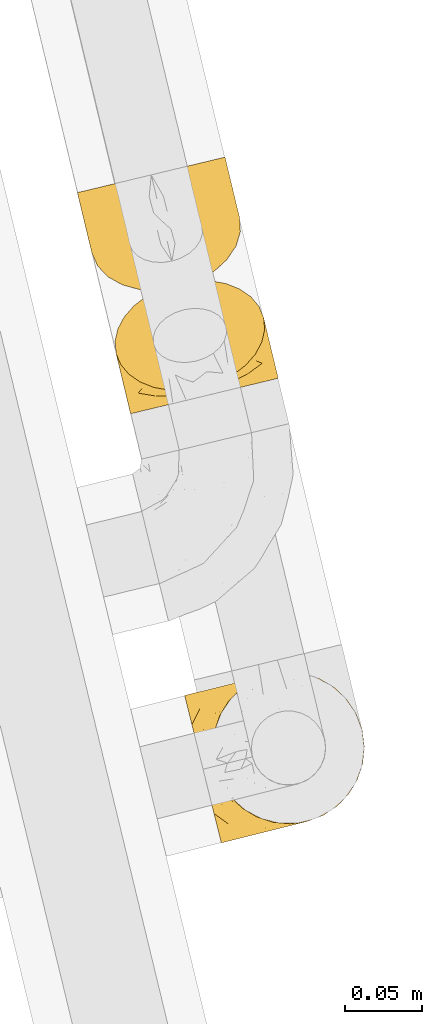
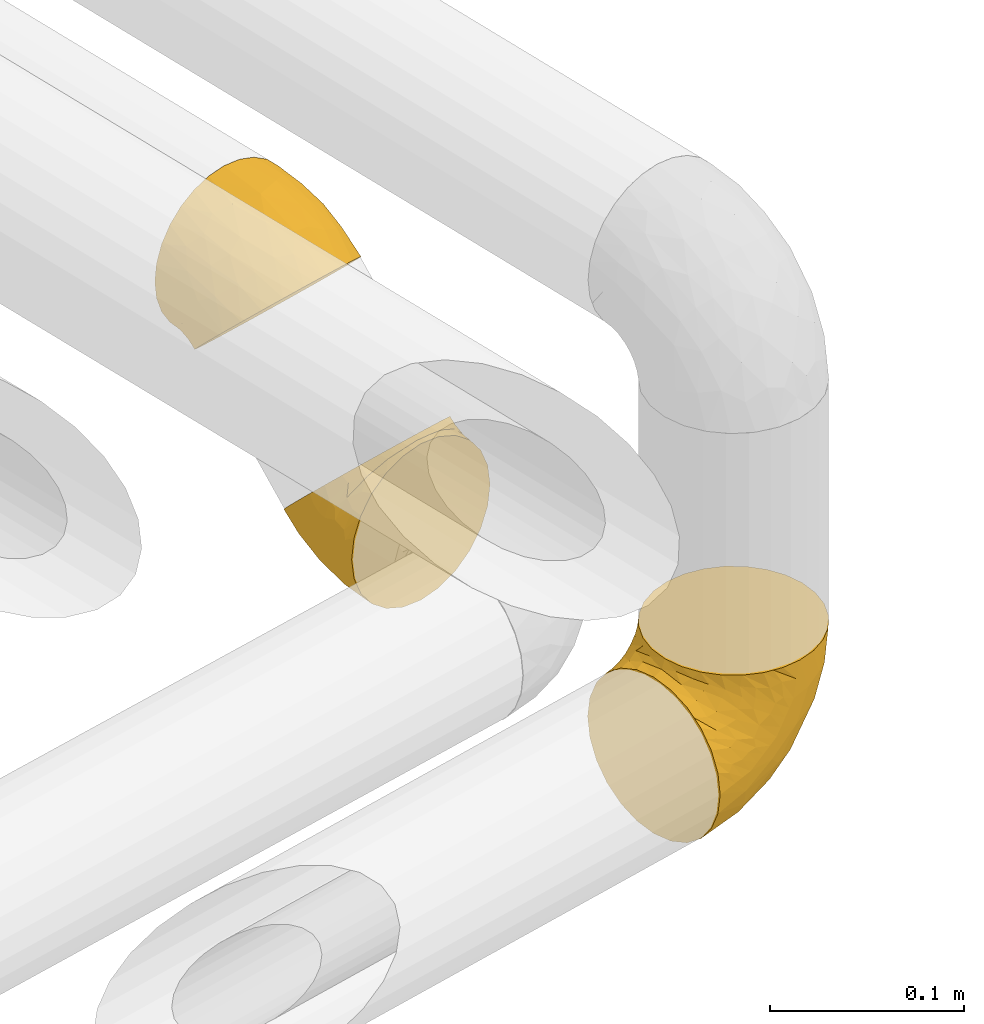
# One storey, part 8 of 93: 3 coverings.
"""IFC2X3 building model written with IfcOpenShell, lengths in millimetres."""

from ifc_helpers import new_model, entity, si_unit, converted_unit, derived_unit, direction, frame, origin, place, context, subcontext, project, spatial, faceted_brep, element, save


model = new_model("IFC2X3")

# Units and contexts
model_context = context("Model", 3, precision=0.01, world=origin(), true_north=direction((6.12303176911189e-17, 1.0)))
body_context = subcontext(model_context, "Body", "Model", "MODEL_VIEW")
ifc_project = project(units=[si_unit("LENGTHUNIT", "METRE", prefix="MILLI"), si_unit("AREAUNIT", "SQUARE_METRE"), si_unit("VOLUMEUNIT", "CUBIC_METRE"), converted_unit("PLANEANGLEUNIT", "DEGREE", entity("IfcRatioMeasure", 0.0174532925199433), si_unit("PLANEANGLEUNIT", "RADIAN"), dimensions=[0, 0, 0, 0, 0, 0, 0]), si_unit("MASSUNIT", "GRAM", prefix="KILO"), derived_unit("MASSDENSITYUNIT", [(si_unit("MASSUNIT", "GRAM", prefix="KILO"), 1), (si_unit("LENGTHUNIT", "METRE"), -3)]), derived_unit("MOMENTOFINERTIAUNIT", [(si_unit("LENGTHUNIT", "METRE"), 4)]), si_unit("TIMEUNIT", "SECOND"), si_unit("FREQUENCYUNIT", "HERTZ"), si_unit("THERMODYNAMICTEMPERATUREUNIT", "DEGREE_CELSIUS"), derived_unit("THERMALTRANSMITTANCEUNIT", [(si_unit("MASSUNIT", "GRAM", prefix="KILO"), 1), (si_unit("THERMODYNAMICTEMPERATUREUNIT", "KELVIN"), -1), (si_unit("TIMEUNIT", "SECOND"), -3)]), derived_unit("VOLUMETRICFLOWRATEUNIT", [(si_unit("LENGTHUNIT", "METRE"), 3), (si_unit("TIMEUNIT", "SECOND"), -1)]), derived_unit("MASSFLOWRATEUNIT", [(si_unit("MASSUNIT", "GRAM", prefix="KILO"), 1), (si_unit("TIMEUNIT", "SECOND"), -1)]), derived_unit("ROTATIONALFREQUENCYUNIT", [(si_unit("TIMEUNIT", "SECOND"), -1)]), si_unit("ELECTRICCURRENTUNIT", "AMPERE"), si_unit("ELECTRICVOLTAGEUNIT", "VOLT"), si_unit("POWERUNIT", "WATT"), si_unit("FORCEUNIT", "NEWTON", prefix="KILO"), si_unit("ILLUMINANCEUNIT", "LUX"), si_unit("LUMINOUSFLUXUNIT", "LUMEN"), si_unit("LUMINOUSINTENSITYUNIT", "CANDELA"), derived_unit("USERDEFINED", [(si_unit("MASSUNIT", "GRAM", prefix="KILO"), -1), (si_unit("LENGTHUNIT", "METRE"), -2), (si_unit("TIMEUNIT", "SECOND"), 3), (si_unit("LUMINOUSFLUXUNIT", "LUMEN"), 1)]), derived_unit("LINEARVELOCITYUNIT", [(si_unit("LENGTHUNIT", "METRE"), 1), (si_unit("TIMEUNIT", "SECOND"), -1)]), si_unit("PRESSUREUNIT", "PASCAL"), derived_unit("USERDEFINED", [(si_unit("LENGTHUNIT", "METRE"), -2), (si_unit("MASSUNIT", "GRAM", prefix="KILO"), 1), (si_unit("TIMEUNIT", "SECOND"), -2)]), derived_unit("LINEARFORCEUNIT", [(si_unit("MASSUNIT", "GRAM", prefix="KILO"), 1), (si_unit("LENGTHUNIT", "METRE"), 1), (si_unit("TIMEUNIT", "SECOND"), -2), (si_unit("LENGTHUNIT", "METRE"), -1)]), derived_unit("PLANARFORCEUNIT", [(si_unit("MASSUNIT", "GRAM", prefix="KILO"), 1), (si_unit("LENGTHUNIT", "METRE"), 1), (si_unit("TIMEUNIT", "SECOND"), -2), (si_unit("LENGTHUNIT", "METRE"), -2)])], contexts=[model_context])

# Site, building, storey
site_placement = place(None, origin())
site = spatial("IfcSite", under=ifc_project, at=site_placement, CompositionType="ELEMENT")
building_placement = place(site_placement, origin())
building = spatial("IfcBuilding", under=site, at=building_placement, CompositionType="ELEMENT")
storey_placement = place(building_placement, frame((0.0, 0.0, -4200.0)))
storey = spatial("IfcBuildingStorey", under=building, at=storey_placement, CompositionType="ELEMENT", Elevation=-4200.0)

# Coverings
covering_1_placement = place(storey_placement, frame((-14676.7, 9890.49, 2242.1)))
element("IfcCovering", 1, at=covering_1_placement, inside=storey, Name=":ADSK_", ObjectType=":ADSK_", PredefinedType="INSULATION", context=body_context, shape_type="Brep", body=[
    faceted_brep([(58.12, 18.49, 102.19), (68.56, 21.89, 101.32), (78.06, 26.82, 98.75), (86.15, 33.03, 94.61), (92.43, 40.2, 89.1), (96.58, 47.98, 82.51), (98.39, 55.97, 75.17), (97.78, 63.77, 67.44), (94.77, 71.01, 59.7), (89.52, 77.3, 52.36), (82.28, 82.34, 45.77), (73.43, 85.86, 40.26), (63.4, 87.71, 36.13), (52.7, 87.78, 33.56), (41.87, 86.07, 32.69), (31.43, 82.66, 33.56), (21.93, 77.73, 36.13), (13.84, 71.52, 40.27), (7.56, 64.35, 45.78), (3.41, 56.58, 52.37), (1.6, 48.59, 59.71), (2.21, 40.78, 67.44), (5.22, 33.55, 75.18), (10.47, 27.26, 82.52), (17.71, 22.22, 89.11), (26.56, 18.69, 94.62), (36.59, 16.85, 98.76), (47.29, 16.78, 101.32), (47.05, 10.11, 98.22), (35.53, 7.34, 93.31), (25.63, 4.96, 85.5), (18.03, 3.14, 75.32), (13.26, 1.99, 63.47), (12.77, 1.87, 59.62), (11.63, 1.6, 50.75), (13.26, 1.99, 38.02), (18.03, 3.14, 26.17), (25.63, 4.96, 15.99), (35.53, 7.34, 8.18), (47.05, 10.11, 3.27), (59.42, 13.09, 1.6), (71.79, 16.06, 3.27), (83.31, 18.84, 8.18), (93.21, 21.22, 15.99), (100.8, 23.04, 26.17), (105.58, 24.19, 38.02), (107.21, 24.58, 50.75), (106.07, 24.31, 59.62), (105.58, 24.19, 63.47), (103.19, 23.62, 69.39), (100.8, 23.04, 75.32), (93.21, 21.22, 85.5), (83.31, 18.84, 93.31), (71.79, 16.06, 98.22), (59.42, 13.09, 99.9), (80.67, 68.77, 29.05), (52.99, 39.8, 5.21), (63.67, 32.15, 3.82), (83.24, 38.1, 12.9), (72.08, 37.49, 7.13), (74.06, 56.4, 15.87), (91.01, 39.39, 20.1), (59.87, 52.99, 9.95), (90.53, 54.91, 29.0), (83.18, 53.18, 20.01), (95.24, 59.28, 41.95), (98.61, 41.06, 32.31), (101.26, 44.36, 43.35), (98.68, 57.64, 53.13), (102.1, 45.79, 55.08), (70.71, 73.77, 26.09), (61.47, 70.5, 20.08), (47.01, 64.69, 15.82), (87.92, 69.57, 38.7), (103.39, 40.46, 53.99), (104.67, 35.12, 52.9), (105.3, 32.49, 52.36), (105.94, 29.85, 51.82), (98.85, 59.3, 64.37), (99.93, 54.84, 61.3), (101.02, 50.32, 58.19), (76.66, 22.03, 97.11), (101.81, 38.34, 67.29), (103.62, 31.67, 64.71), (101.27, 44.82, 65.8), (99.7, 39.76, 73.34), (87.6, 27.5, 90.61), (93.5, 27.2, 84.43), (96.8, 34.29, 79.81), (104.87, 28.8, 62.16), (99.38, 53.25, 70.51), (100.31, 49.62, 67.49), (67.62, 18.29, 99.62), (99.23, 29.32, 76.08), (93.0, 35.83, 86.26), (98.8, 43.62, 75.44), (58.72, 16.01, 100.49), (22.65, 10.17, 84.44), (27.79, 13.11, 90.63), (16.58, 9.44, 76.08), (49.76, 14.0, 99.62), (40.01, 13.21, 97.12), (3.28, 36.32, 64.37), (16.5, 14.97, 79.83), (10.36, 6.86, 51.82), (11.08, 7.29, 59.87), (19.19, 18.06, 86.27), (11.6, 9.53, 64.71), (6.53, 22.8, 55.08), (10.19, 16.31, 67.31), (7.72, 22.31, 65.81), (7.81, 17.47, 53.99), (10.47, 22.36, 75.46), (4.36, 31.85, 61.3), (5.56, 30.68, 70.51), (6.39, 27.03, 67.5), (11.43, 18.52, 73.35), (5.44, 27.33, 58.19), (9.1, 12.13, 52.9), (6.51, 37.93, 41.96), (7.93, 21.92, 43.36), (15.16, 53.0, 29.06), (11.79, 20.17, 32.32), (12.69, 36.18, 29.02), (44.19, 36.52, 5.84), (37.05, 29.07, 7.14), (26.83, 24.53, 12.9), (26.67, 45.0, 15.88), (4.19, 34.91, 53.14), (19.32, 22.15, 20.1), (8.35, 50.42, 38.71), (35.6, 46.95, 11.42), (31.48, 63.28, 20.08), (21.76, 61.99, 26.09), (20.02, 37.99, 20.01)], [[[0, 1, 2, 3, 4, 5, 6, 7, 8, 9, 10, 11, 12, 13, 14, 15, 16, 17, 18, 19, 20, 21, 22, 23, 24, 25, 26, 27]], [[28, 29, 30, 31, 32, 33, 34, 35, 36, 37, 38, 39, 40, 41, 42, 43, 44, 45, 46, 47, 48, 49, 50, 51, 52, 53, 54]], [[10, 55, 11]], [[40, 56, 57]], [[42, 58, 43]], [[59, 60, 58]], [[61, 44, 43]], [[60, 59, 62]], [[63, 61, 64]], [[63, 65, 66]], [[67, 46, 45]], [[66, 67, 45]], [[42, 41, 59]], [[67, 68, 69]], [[58, 61, 43]], [[70, 60, 71]], [[71, 62, 72]], [[72, 13, 71]], [[55, 70, 11]], [[12, 70, 71]], [[59, 58, 42]], [[14, 13, 72]], [[73, 55, 10]], [[67, 69, 74, 75, 76, 77, 46]], [[41, 57, 59]], [[68, 7, 78, 79, 80, 69]], [[9, 8, 65]], [[73, 65, 63]], [[45, 44, 66]], [[67, 66, 65]], [[9, 73, 10]], [[57, 62, 59]], [[68, 65, 8]], [[12, 71, 13]], [[60, 55, 64]], [[66, 44, 61]], [[64, 61, 58]], [[61, 63, 66]], [[60, 64, 58]], [[63, 64, 55]], [[65, 73, 9]], [[55, 73, 63]], [[65, 68, 67]], [[7, 68, 8]], [[11, 70, 12]], [[55, 60, 70]], [[40, 57, 41]], [[62, 57, 56]], [[72, 62, 56]], [[62, 71, 60]], [[52, 81, 53]], [[82, 83, 74]], [[84, 85, 82]], [[86, 87, 88]], [[77, 89, 48]], [[87, 52, 51]], [[90, 5, 91]], [[92, 1, 0]], [[86, 2, 81]], [[54, 53, 92]], [[52, 86, 81]], [[93, 51, 50]], [[87, 51, 93]], [[83, 93, 50]], [[94, 95, 4]], [[5, 4, 95]], [[5, 95, 91]], [[7, 6, 78]], [[94, 88, 85]], [[86, 94, 3]], [[48, 47, 46, 77]], [[96, 92, 0]], [[80, 91, 84]], [[2, 1, 81]], [[3, 2, 86]], [[90, 78, 6]], [[1, 92, 81]], [[94, 86, 88]], [[82, 93, 83]], [[3, 94, 4]], [[80, 84, 69]], [[82, 88, 93]], [[49, 48, 89]], [[69, 82, 74]], [[83, 75, 74]], [[88, 87, 93]], [[52, 87, 86]], [[91, 80, 79]], [[91, 79, 90]], [[84, 91, 95]], [[85, 84, 95]], [[69, 84, 82]], [[78, 90, 79]], [[5, 90, 6]], [[94, 85, 95]], [[82, 85, 88]], [[54, 92, 96]], [[81, 92, 53]], [[83, 89, 75]], [[77, 76, 75, 89]], [[83, 49, 89]], [[83, 50, 49]], [[97, 29, 98]], [[30, 99, 31]], [[100, 101, 28]], [[22, 21, 102]], [[103, 99, 97]], [[101, 29, 28]], [[104, 33, 105]], [[98, 106, 103]], [[107, 31, 99]], [[97, 99, 30]], [[108, 109, 110]], [[26, 98, 101]], [[54, 96, 100]], [[109, 111, 107]], [[0, 27, 100]], [[112, 106, 24]], [[101, 27, 26]], [[102, 113, 114]], [[105, 31, 107]], [[25, 98, 26]], [[24, 106, 25]], [[112, 24, 23]], [[106, 98, 25]], [[23, 22, 114]], [[112, 115, 110]], [[113, 115, 114]], [[29, 101, 98]], [[112, 116, 106]], [[29, 97, 30]], [[96, 0, 100]], [[115, 113, 117]], [[103, 109, 99]], [[109, 107, 99]], [[105, 107, 118]], [[111, 109, 108]], [[111, 118, 107]], [[103, 97, 98]], [[110, 116, 112]], [[110, 115, 117]], [[23, 115, 112]], [[108, 110, 117]], [[116, 109, 103]], [[23, 114, 115]], [[102, 114, 22]], [[109, 116, 110]], [[106, 116, 103]], [[104, 34, 33]], [[33, 32, 105]], [[101, 100, 27]], [[54, 100, 28]], [[104, 105, 118]], [[31, 105, 32]], [[20, 19, 119]], [[35, 34, 120]], [[120, 34, 104, 118, 111, 108]], [[121, 18, 17]], [[36, 35, 122]], [[122, 119, 123]], [[39, 124, 40]], [[125, 126, 127]], [[125, 39, 38]], [[128, 120, 108]], [[129, 36, 122]], [[38, 126, 125]], [[129, 126, 37]], [[37, 126, 38]], [[120, 128, 119]], [[35, 120, 122]], [[119, 19, 130]], [[131, 127, 132]], [[130, 19, 18]], [[133, 17, 16]], [[134, 127, 126]], [[123, 130, 121]], [[125, 127, 131]], [[16, 132, 133]], [[15, 14, 72]], [[72, 56, 124]], [[15, 72, 132]], [[133, 132, 127]], [[123, 129, 122]], [[15, 132, 16]], [[119, 122, 120]], [[128, 21, 20]], [[39, 125, 124]], [[126, 129, 134]], [[36, 129, 37]], [[134, 123, 121]], [[123, 134, 129]], [[127, 134, 121]], [[121, 130, 18]], [[119, 130, 123]], [[128, 108, 117, 113, 102, 21]], [[119, 128, 20]], [[127, 121, 133]], [[17, 133, 121]], [[72, 131, 132]], [[124, 125, 131]], [[72, 124, 131]], [[124, 56, 40]]]),
])
covering_2_placement = place(storey_placement, frame((-14701.1, 9970.32, 2339.8)))
element("IfcCovering", 2, at=covering_2_placement, inside=storey, Name=":ADSK_", ObjectType=":ADSK_", PredefinedType="INSULATION", context=body_context, shape_type="Brep", body=[
    faceted_brep([(2.79, 65.19, 42.11), (1.6, 64.9, 53.04), (2.79, 65.19, 63.99), (6.33, 66.04, 74.38), (12.03, 67.41, 83.7), (19.59, 69.23, 91.48), (28.66, 71.41, 97.33), (38.75, 73.84, 100.96), (49.38, 76.4, 102.19), (60.02, 78.96, 100.96), (70.12, 81.39, 97.32), (79.18, 83.57, 91.47), (86.75, 85.38, 83.68), (92.44, 86.75, 74.36), (95.97, 87.6, 63.98), (97.17, 87.89, 53.04), (95.97, 87.6, 42.1), (92.43, 86.75, 31.71), (86.74, 85.38, 22.39), (79.17, 83.56, 14.61), (70.11, 81.38, 8.76), (60.01, 78.95, 5.13), (49.38, 76.4, 3.89), (38.74, 73.84, 5.13), (28.64, 71.41, 8.77), (19.58, 69.23, 14.62), (12.02, 67.41, 22.41), (6.32, 66.04, 31.73), (11.02, 25.71, 36.35), (10.69, 32.09, 30.07), (10.55, 34.85, 27.35), (11.95, 39.5, 23.16), (13.36, 44.15, 18.97), (19.27, 52.97, 11.77), (27.88, 60.73, 6.25), (38.59, 66.87, 2.78), (50.68, 71.0, 1.6), (63.33, 72.82, 2.78), (75.66, 72.22, 6.25), (86.85, 69.23, 11.77), (96.13, 64.06, 18.97), (102.86, 57.06, 27.35), (103.99, 54.54, 30.07), (106.6, 48.7, 36.35), (107.07, 39.57, 45.34), (104.26, 30.27, 53.73), (98.35, 21.44, 60.92), (89.74, 13.69, 66.45), (79.03, 7.55, 69.92), (66.94, 3.42, 71.1), (54.29, 1.6, 69.92), (41.95, 2.2, 66.45), (30.77, 5.19, 60.92), (21.49, 10.36, 53.73), (14.75, 17.36, 45.34), (21.51, 48.22, 86.45), (61.79, 24.79, 87.97), (55.32, 15.0, 81.93), (33.76, 17.3, 76.36), (45.08, 17.29, 81.87), (34.49, 34.13, 88.36), (25.03, 20.02, 70.88), (49.66, 33.48, 92.55), (17.97, 35.85, 75.33), (26.78, 31.46, 81.72), (9.86, 45.6, 68.4), (15.47, 26.49, 62.14), (9.96, 35.08, 56.16), (5.53, 50.96, 58.8), (6.7, 43.69, 48.71), (29.1, 53.12, 93.64), (39.74, 50.57, 97.16), (55.81, 49.69, 98.58), (13.04, 52.53, 78.98), (7.78, 39.17, 45.6), (8.87, 34.65, 42.49), (9.41, 32.42, 40.95), (9.95, 30.18, 39.42), (2.86, 59.63, 51.97), (4.13, 54.36, 50.89), (5.41, 49.03, 49.8), (32.04, 67.88, 6.86), (7.84, 47.63, 35.0), (9.21, 41.05, 31.94), (6.06, 50.79, 40.6), (8.2, 53.48, 32.05), (21.07, 62.53, 13.41), (16.86, 55.8, 16.6), (11.88, 55.69, 24.2), (9.62, 37.06, 31.56), (3.72, 59.93, 43.37), (4.79, 55.27, 42.87), (41.28, 70.82, 4.01), (12.22, 49.13, 23.01), (13.67, 62.54, 21.32), (7.17, 57.64, 33.36), (50.08, 73.48, 3.3), (87.71, 72.85, 16.6), (80.88, 76.92, 13.4), (94.88, 69.01, 23.01), (59.14, 75.11, 4.01), (68.69, 76.7, 6.85), (98.44, 82.62, 51.97), (92.18, 75.02, 24.17), (105.52, 53.17, 39.42), (103.38, 58.69, 33.9), (87.48, 80.3, 21.3), (101.23, 63.19, 31.94), (102.27, 66.68, 48.71), (99.46, 69.68, 34.99), (99.61, 73.29, 40.59), (103.36, 62.16, 45.6), (95.5, 78.89, 33.34), (99.7, 77.35, 50.89), (97.54, 82.5, 43.38), (98.7, 77.87, 42.85), (96.47, 74.71, 32.03), (100.99, 72.02, 49.8), (104.45, 57.64, 42.49), (98.59, 66.95, 68.39), (103.28, 57.54, 56.15), (87.03, 63.98, 86.44), (102.29, 47.37, 62.12), (95.81, 54.58, 75.32), (70.95, 26.63, 86.73), (80.1, 25.72, 81.87), (90.17, 30.86, 76.36), (81.88, 45.54, 88.35), (100.01, 73.68, 58.8), (96.71, 37.27, 70.88), (92.61, 71.67, 78.97), (73.76, 40.2, 91.37), (69.73, 57.78, 97.16), (78.04, 64.89, 93.63), (89.94, 46.65, 81.72)], [[[0, 1, 2, 3, 4, 5, 6, 7, 8, 9, 10, 11, 12, 13, 14, 15, 16, 17, 18, 19, 20, 21, 22, 23, 24, 25, 26, 27]], [[28, 29, 30, 31, 32, 33, 34, 35, 36, 37, 38, 39, 40, 41, 42, 43, 44, 45, 46, 47, 48, 49, 50, 51, 52, 53, 54]], [[4, 55, 5]], [[49, 56, 57]], [[51, 58, 52]], [[59, 60, 58]], [[61, 53, 52]], [[60, 59, 62]], [[63, 61, 64]], [[63, 65, 66]], [[67, 28, 54]], [[66, 67, 54]], [[51, 50, 59]], [[67, 68, 69]], [[58, 61, 52]], [[70, 60, 71]], [[71, 62, 72]], [[72, 7, 71]], [[55, 70, 5]], [[6, 70, 71]], [[59, 58, 51]], [[8, 7, 72]], [[73, 55, 4]], [[67, 69, 74, 75, 76, 77, 28]], [[50, 57, 59]], [[68, 1, 78, 79, 80, 69]], [[3, 2, 65]], [[73, 65, 63]], [[54, 53, 66]], [[67, 66, 65]], [[3, 73, 4]], [[57, 62, 59]], [[68, 65, 2]], [[6, 71, 7]], [[60, 55, 64]], [[66, 53, 61]], [[64, 61, 58]], [[61, 63, 66]], [[60, 64, 58]], [[63, 64, 55]], [[65, 73, 3]], [[55, 73, 63]], [[65, 68, 67]], [[1, 68, 2]], [[5, 70, 6]], [[55, 60, 70]], [[49, 57, 50]], [[62, 57, 56]], [[72, 62, 56]], [[62, 71, 60]], [[34, 81, 35]], [[82, 83, 74]], [[84, 85, 82]], [[86, 87, 88]], [[77, 89, 30]], [[87, 34, 33]], [[90, 27, 91]], [[92, 23, 22]], [[86, 24, 81]], [[36, 35, 92]], [[34, 86, 81]], [[93, 33, 32]], [[87, 33, 93]], [[83, 93, 32]], [[94, 95, 26]], [[27, 26, 95]], [[27, 95, 91]], [[1, 0, 78]], [[94, 88, 85]], [[86, 94, 25]], [[30, 29, 28, 77]], [[96, 92, 22]], [[80, 91, 84]], [[24, 23, 81]], [[25, 24, 86]], [[90, 78, 0]], [[23, 92, 81]], [[94, 86, 88]], [[82, 93, 83]], [[25, 94, 26]], [[80, 84, 69]], [[82, 88, 93]], [[31, 30, 89]], [[69, 82, 74]], [[83, 75, 74]], [[88, 87, 93]], [[34, 87, 86]], [[91, 80, 79]], [[91, 79, 90]], [[84, 91, 95]], [[85, 84, 95]], [[69, 84, 82]], [[78, 90, 79]], [[27, 90, 0]], [[94, 85, 95]], [[82, 85, 88]], [[36, 92, 96]], [[81, 92, 35]], [[83, 89, 75]], [[77, 76, 75, 89]], [[83, 31, 89]], [[83, 32, 31]], [[97, 38, 98]], [[39, 99, 40]], [[100, 101, 37]], [[16, 15, 102]], [[103, 99, 97]], [[101, 38, 37]], [[104, 42, 105]], [[98, 106, 103]], [[107, 40, 99]], [[97, 99, 39]], [[108, 109, 110]], [[20, 98, 101]], [[36, 96, 100]], [[109, 111, 107]], [[22, 21, 100]], [[112, 106, 18]], [[101, 21, 20]], [[102, 113, 114]], [[105, 40, 107]], [[19, 98, 20]], [[18, 106, 19]], [[112, 18, 17]], [[106, 98, 19]], [[17, 16, 114]], [[112, 115, 110]], [[113, 115, 114]], [[38, 101, 98]], [[112, 116, 106]], [[38, 97, 39]], [[96, 22, 100]], [[115, 113, 117]], [[103, 109, 99]], [[109, 107, 99]], [[105, 107, 118]], [[111, 109, 108]], [[111, 118, 107]], [[103, 97, 98]], [[110, 116, 112]], [[110, 115, 117]], [[17, 115, 112]], [[108, 110, 117]], [[116, 109, 103]], [[17, 114, 115]], [[102, 114, 16]], [[109, 116, 110]], [[106, 116, 103]], [[104, 43, 42]], [[42, 41, 105]], [[101, 100, 21]], [[36, 100, 37]], [[104, 105, 118]], [[40, 105, 41]], [[14, 13, 119]], [[44, 43, 120]], [[120, 43, 104, 118, 111, 108]], [[121, 12, 11]], [[45, 44, 122]], [[122, 119, 123]], [[48, 124, 49]], [[125, 126, 127]], [[125, 48, 47]], [[128, 120, 108]], [[129, 45, 122]], [[47, 126, 125]], [[129, 126, 46]], [[46, 126, 47]], [[120, 128, 119]], [[44, 120, 122]], [[119, 13, 130]], [[131, 127, 132]], [[130, 13, 12]], [[133, 11, 10]], [[134, 127, 126]], [[123, 130, 121]], [[125, 127, 131]], [[10, 132, 133]], [[9, 8, 72]], [[72, 56, 124]], [[9, 72, 132]], [[133, 132, 127]], [[123, 129, 122]], [[9, 132, 10]], [[119, 122, 120]], [[128, 15, 14]], [[48, 125, 124]], [[126, 129, 134]], [[45, 129, 46]], [[134, 123, 121]], [[123, 134, 129]], [[127, 134, 121]], [[121, 130, 12]], [[119, 130, 123]], [[128, 108, 117, 113, 102, 15]], [[119, 128, 14]], [[127, 121, 133]], [[11, 133, 121]], [[72, 131, 132]], [[124, 125, 131]], [[72, 124, 131]], [[124, 56, 49]]]),
])
covering_3_placement = place(storey_placement, frame((-14631.67, 9612.73, 2242.1)))
element("IfcCovering", 3, at=covering_3_placement, inside=storey, Name=":ADSK_", ObjectType=":ADSK_", PredefinedType="INSULATION", context=body_context, shape_type="Brep", body=[
    faceted_brep([(80.68, 15.38, 107.75), (91.0, 19.23, 107.75), (100.2, 25.27, 107.75), (107.83, 33.21, 107.75), (113.5, 42.65, 107.75), (116.92, 53.1, 107.75), (117.93, 64.06, 107.75), (116.48, 74.97, 107.75), (112.64, 85.28, 107.75), (106.6, 94.49, 107.75), (98.66, 102.11, 107.75), (89.22, 107.78, 107.75), (78.76, 111.2, 107.75), (67.81, 112.21, 107.75), (56.9, 110.76, 107.75), (51.53, 108.76, 107.75), (46.58, 106.92, 107.75), (41.98, 103.9, 107.75), (37.38, 100.88, 107.75), (29.76, 92.94, 107.75), (24.09, 83.5, 107.75), (20.66, 73.05, 107.75), (19.65, 62.09, 107.75), (21.1, 51.18, 107.75), (24.95, 40.87, 107.75), (30.99, 31.66, 107.75), (38.93, 24.04, 107.75), (48.36, 18.37, 107.75), (58.82, 14.95, 107.75), (64.3, 14.44, 107.75), (69.78, 13.93, 107.75), (75.0, 14.63, 107.75), (77.84, 15.01, 107.75), (10.41, 61.63, 98.22), (7.54, 73.13, 93.31), (6.31, 78.07, 89.4), (5.08, 83.01, 85.5), (4.13, 86.8, 80.41), (3.19, 90.59, 75.32), (2.59, 92.97, 69.39), (2.0, 95.35, 63.47), (1.78, 96.24, 56.48), (1.69, 96.61, 53.61), (1.6, 96.98, 50.75), (2.0, 95.35, 38.02), (3.19, 90.59, 26.17), (5.08, 83.01, 15.99), (7.54, 73.13, 8.18), (10.41, 61.63, 3.27), (13.49, 49.29, 1.6), (16.56, 36.94, 3.27), (19.43, 25.44, 8.18), (21.89, 15.56, 15.99), (23.78, 7.98, 26.17), (24.97, 3.22, 38.02), (25.38, 1.6, 50.75), (25.19, 2.33, 56.48), (24.97, 3.22, 63.47), (24.38, 5.6, 69.39), (23.78, 7.98, 75.32), (22.84, 11.77, 80.41), (21.89, 15.56, 85.5), (20.66, 20.5, 89.4), (19.43, 25.44, 93.31), (16.56, 36.94, 98.22), (13.49, 49.29, 99.9), (81.89, 57.52, 27.53), (75.16, 41.65, 25.32), (65.49, 48.88, 16.29), (45.31, 57.22, 6.79), (36.53, 46.89, 4.51), (25.21, 52.21, 3.51), (58.52, 33.73, 17.47), (41.51, 38.82, 7.6), (38.34, 26.44, 12.27), (92.66, 24.13, 70.89), (87.47, 18.25, 87.17), (79.31, 16.59, 67.3), (45.6, 12.13, 31.65), (66.53, 22.15, 33.58), (68.15, 15.94, 47.23), (44.1, 7.41, 43.26), (46.54, 6.87, 55.08), (41.22, 5.54, 53.99), (35.89, 4.22, 52.9), (33.26, 3.56, 52.36), (30.63, 2.91, 51.82), (46.76, 19.89, 21.5), (97.1, 23.9, 89.94), (106.99, 62.62, 60.45), (114.97, 59.65, 83.0), (107.42, 49.91, 64.79), (76.47, 14.34, 85.93), (73.48, 13.59, 81.31), (70.48, 12.84, 76.69), (67.48, 12.09, 72.06), (64.48, 11.35, 67.44), (104.22, 30.79, 88.74), (98.35, 57.67, 45.98), (79.7, 23.39, 47.13), (114.41, 49.19, 89.4), (114.63, 74.5, 95.66), (71.54, 31.36, 28.5), (85.25, 31.79, 42.81), (87.71, 40.81, 38.28), (96.81, 70.06, 45.35), (85.42, 67.22, 33.61), (109.24, 39.9, 82.57), (80.16, 15.25, 105.04), (79.64, 15.12, 102.33), (78.59, 14.86, 96.91), (77.53, 14.6, 91.42), (99.65, 33.27, 65.92), (97.19, 39.13, 53.11), (61.92, 11.46, 54.37), (111.44, 73.71, 74.94), (60.0, 10.23, 64.35), (55.51, 9.11, 61.26), (51.03, 7.99, 58.17), (74.03, 64.38, 21.87), (88.35, 50.57, 34.79), (98.28, 48.26, 48.48), (104.13, 71.88, 60.15), (59.67, 60.8, 14.33), (69.1, 13.74, 99.07), (32.13, 4.19, 60.55), (41.3, 6.7, 64.18), (34.77, 5.59, 64.36), (27.67, 34.52, 103.17), (33.47, 27.39, 101.69), (64.73, 12.81, 87.75), (69.68, 13.26, 89.38), (27.58, 18.97, 88.34), (30.3, 13.57, 82.14), (25.73, 26.55, 94.51), (33.19, 19.04, 89.64), (30.67, 27.66, 98.41), (22.48, 37.07, 99.71), (44.4, 15.68, 89.37), (52.1, 13.7, 88.21), (47.27, 16.87, 95.2), (28.28, 11.3, 79.14), (35.15, 8.51, 72.69), (46.78, 18.53, 101.22), (40.16, 21.55, 99.41), (41.92, 14.12, 84.72), (62.16, 13.89, 97.47), (18.87, 50.63, 102.19), (22.94, 43.16, 104.02), (61.09, 12.07, 82.66), (37.69, 21.13, 95.42), (54.09, 11.2, 78.67), (45.83, 7.87, 66.46), (39.73, 9.96, 75.3), (50.19, 9.69, 72.74), (36.37, 13.86, 82.93), (54.55, 15.45, 99.27), (53.91, 14.62, 93.51), (50.7, 8.73, 67.35), (13.62, 75.1, 94.51), (17.05, 91.3, 82.94), (11.69, 82.67, 88.33), (16.67, 85.22, 89.64), (19.75, 71.77, 103.62), (41.6, 105.55, 87.74), (46.19, 107.48, 89.38), (49.69, 108.97, 81.31), (39.83, 103.38, 97.47), (24.01, 86.28, 99.41), (4.22, 97.63, 51.28), (12.11, 99.6, 52.9), (6.85, 98.29, 51.82), (28.42, 92.05, 101.21), (28.09, 93.76, 95.19), (11.77, 97.86, 64.36), (13.47, 95.46, 72.69), (11.56, 88.72, 82.13), (18.19, 96.33, 75.3), (8.71, 89.77, 79.14), (33.82, 98.41, 99.28), (32.89, 98.86, 93.51), (8.77, 97.86, 60.55), (22.6, 101.04, 66.46), (18.23, 100.05, 63.96), (54.81, 110.24, 96.91), (45.9, 106.78, 99.06), (15.68, 64.3, 99.7), (17.44, 100.92, 53.99), (22.76, 102.25, 55.08), (18.55, 63.08, 103.3), (55.86, 110.5, 102.33), (55.33, 110.37, 99.62), (46.7, 108.22, 76.69), (38.04, 104.49, 82.66), (21.63, 85.49, 95.42), (43.7, 107.47, 72.06), (31.42, 101.95, 78.68), (30.87, 98.84, 88.2), (27.31, 101.47, 72.75), (22.06, 93.66, 84.74), (53.75, 109.98, 91.42), (52.69, 109.72, 85.93), (18.5, 76.43, 98.41), (24.99, 93.46, 89.37), (27.31, 102.57, 67.35), (31.73, 104.49, 61.26), (27.25, 103.37, 58.17), (36.22, 105.61, 64.35), (40.7, 106.73, 67.44), (38.8, 105.42, 54.08), (32.71, 62.22, 4.51), (29.07, 90.86, 21.5), (47.27, 98.1, 33.43), (56.27, 92.39, 28.5), (45.95, 84.17, 17.47), (64.37, 85.03, 25.36), (75.61, 110.94, 90.18), (64.48, 111.42, 86.97), (20.86, 100.63, 43.26), (59.21, 74.05, 16.29), (33.32, 71.69, 7.6), (24.71, 81.12, 12.27), (24.39, 97.17, 31.65), (96.7, 92.85, 64.79), (107.95, 87.79, 83.0), (102.29, 81.42, 60.44), (75.1, 91.64, 38.35), (80.19, 83.3, 34.8), (71.74, 108.78, 71.54), (92.34, 81.69, 45.94), (77.75, 74.13, 27.53), (93.61, 102.54, 82.57), (84.9, 108.22, 88.74), (82.73, 97.53, 53.19), (87.91, 89.97, 48.49), (56.28, 109.06, 67.28), (63.67, 104.64, 52.32), (102.54, 96.76, 89.4), (81.95, 103.87, 65.75), (46.65, 104.23, 46.73), (68.63, 98.44, 42.82)], [[[0, 1, 2, 3, 4, 5, 6, 7, 8, 9, 10, 11, 12, 13, 14, 15, 16, 17, 18, 19, 20, 21, 22, 23, 24, 25, 26, 27, 28, 29, 30, 31, 32]], [[33, 34, 35, 36, 37, 38, 39, 40, 41, 42, 43, 44, 45, 46, 47, 48, 49, 50, 51, 52, 53, 54, 55, 56, 57, 58, 59, 60, 61, 62, 63, 64, 65]], [[66, 67, 68]], [[69, 70, 71]], [[68, 72, 73]], [[73, 72, 74]], [[75, 76, 77]], [[78, 79, 80]], [[51, 50, 73]], [[81, 82, 83, 84, 85, 86, 55]], [[52, 87, 53]], [[74, 52, 51]], [[2, 1, 88]], [[89, 90, 91]], [[77, 92, 93, 94, 95, 96]], [[55, 54, 81]], [[78, 53, 87]], [[5, 90, 6]], [[88, 76, 75]], [[97, 3, 2]], [[89, 91, 98]], [[99, 80, 79]], [[90, 5, 100]], [[74, 87, 52]], [[100, 5, 4]], [[90, 101, 6]], [[79, 102, 103]], [[102, 67, 104]], [[105, 98, 106]], [[107, 4, 3]], [[76, 0, 108, 109, 110, 111, 92]], [[107, 112, 113]], [[114, 77, 96]], [[89, 115, 90]], [[114, 96, 116, 117, 118, 82]], [[75, 97, 88]], [[119, 66, 68]], [[50, 71, 70]], [[100, 91, 90]], [[99, 77, 80]], [[102, 104, 103]], [[97, 107, 3]], [[80, 81, 78]], [[107, 97, 112]], [[68, 73, 70]], [[66, 98, 120]], [[78, 81, 54]], [[114, 81, 80]], [[53, 78, 54]], [[78, 87, 79]], [[102, 87, 72]], [[79, 103, 99]], [[4, 107, 100]], [[91, 100, 107]], [[88, 97, 2]], [[112, 97, 75]], [[99, 112, 75]], [[103, 104, 113]], [[91, 121, 98]], [[89, 105, 122, 115]], [[101, 90, 115]], [[101, 7, 6]], [[88, 1, 76]], [[0, 76, 1]], [[92, 77, 76]], [[73, 74, 51]], [[87, 74, 72]], [[81, 114, 82]], [[77, 114, 80]], [[87, 102, 79]], [[67, 102, 72]], [[68, 67, 72]], [[67, 120, 104]], [[120, 121, 104]], [[104, 121, 113]], [[121, 120, 98]], [[91, 107, 113]], [[91, 113, 121]], [[103, 113, 112]], [[106, 98, 66]], [[105, 89, 98]], [[106, 66, 119]], [[67, 66, 120]], [[68, 69, 123, 119]], [[50, 49, 71]], [[50, 70, 73]], [[112, 99, 103]], [[77, 99, 75]], [[69, 68, 70]], [[29, 124, 110]], [[84, 83, 125]], [[126, 82, 118]], [[59, 58, 127]], [[25, 128, 129]], [[130, 93, 131]], [[132, 62, 133]], [[134, 135, 136]], [[137, 65, 64]], [[64, 134, 137]], [[138, 139, 140]], [[111, 110, 124, 92]], [[134, 136, 137]], [[134, 64, 63]], [[141, 60, 142]], [[125, 58, 57]], [[143, 144, 140]], [[143, 26, 144]], [[127, 83, 82]], [[28, 124, 29]], [[108, 0, 32, 31, 30, 110, 109]], [[30, 29, 110]], [[135, 145, 138]], [[28, 146, 124]], [[57, 56, 55, 86, 85, 84]], [[147, 148, 23]], [[24, 23, 148]], [[25, 144, 26]], [[95, 94, 149]], [[24, 128, 25]], [[150, 138, 144]], [[124, 146, 131]], [[127, 58, 125]], [[151, 149, 139]], [[127, 126, 142]], [[142, 59, 127]], [[152, 142, 126]], [[153, 154, 155]], [[153, 133, 141]], [[146, 28, 27]], [[143, 156, 27]], [[157, 149, 130]], [[61, 133, 62]], [[134, 132, 135]], [[148, 128, 24]], [[65, 137, 147]], [[147, 137, 148]], [[128, 137, 136]], [[137, 128, 148]], [[128, 136, 129]], [[150, 129, 136]], [[25, 129, 144]], [[158, 152, 117]], [[152, 118, 117]], [[153, 142, 152]], [[158, 116, 154]], [[145, 151, 138]], [[153, 152, 158]], [[133, 153, 155]], [[133, 155, 132]], [[153, 141, 142]], [[135, 132, 155]], [[134, 63, 132]], [[145, 135, 155]], [[135, 138, 150]], [[155, 154, 145]], [[151, 154, 96]], [[154, 151, 145]], [[149, 94, 130]], [[82, 126, 127]], [[118, 152, 126]], [[151, 96, 95]], [[139, 149, 157]], [[151, 95, 149]], [[93, 92, 131]], [[130, 146, 156]], [[130, 94, 93]], [[84, 125, 57]], [[127, 125, 83]], [[140, 139, 157]], [[151, 139, 138]], [[140, 157, 143]], [[138, 140, 144]], [[156, 143, 157]], [[27, 26, 143]], [[130, 156, 157]], [[146, 27, 156]], [[132, 63, 62]], [[124, 131, 92]], [[130, 131, 146]], [[129, 150, 144]], [[135, 150, 136]], [[60, 141, 61]], [[60, 59, 142]], [[133, 61, 141]], [[116, 96, 154]], [[153, 158, 154]], [[158, 117, 116]], [[34, 33, 159]], [[160, 161, 162]], [[22, 21, 163]], [[164, 165, 166]], [[19, 18, 167]], [[168, 21, 20]], [[169, 43, 42, 41, 40, 170, 171]], [[172, 173, 168]], [[174, 38, 175]], [[176, 177, 178]], [[179, 164, 180]], [[40, 181, 170]], [[182, 183, 175]], [[17, 184, 185]], [[65, 147, 186]], [[187, 174, 188]], [[23, 22, 189]], [[174, 39, 38]], [[15, 14, 190, 191, 184, 16]], [[181, 40, 39]], [[192, 193, 164]], [[194, 163, 168]], [[33, 186, 159]], [[180, 173, 172]], [[195, 196, 193]], [[18, 185, 167]], [[173, 180, 197]], [[198, 199, 196]], [[200, 201, 185, 184]], [[184, 17, 16]], [[18, 17, 185]], [[202, 159, 186]], [[194, 168, 203]], [[189, 163, 202]], [[204, 205, 182]], [[187, 181, 174]], [[160, 177, 176]], [[206, 183, 182]], [[206, 182, 205]], [[201, 165, 185]], [[165, 164, 167]], [[172, 179, 180]], [[202, 194, 162]], [[176, 161, 160]], [[65, 186, 33]], [[163, 189, 22]], [[175, 177, 182]], [[174, 183, 188]], [[177, 198, 204]], [[199, 160, 162]], [[198, 207, 204]], [[175, 38, 37]], [[198, 177, 160]], [[178, 177, 175]], [[176, 35, 161]], [[34, 159, 161]], [[162, 161, 159]], [[202, 162, 159]], [[199, 162, 203]], [[196, 199, 203]], [[198, 160, 199]], [[193, 197, 180]], [[208, 198, 196]], [[188, 183, 206]], [[175, 183, 174]], [[193, 192, 195]], [[195, 208, 196]], [[197, 196, 203]], [[180, 164, 193]], [[168, 163, 21]], [[166, 165, 201]], [[166, 192, 164]], [[189, 202, 186]], [[186, 147, 189]], [[23, 189, 147]], [[174, 181, 39]], [[170, 181, 187]], [[196, 197, 193]], [[173, 203, 168]], [[203, 173, 197]], [[172, 168, 20]], [[20, 19, 172]], [[179, 172, 19]], [[19, 167, 179]], [[164, 179, 167]], [[35, 176, 36]], [[35, 34, 161]], [[185, 165, 167]], [[162, 194, 203]], [[163, 194, 202]], [[176, 178, 36]], [[37, 36, 178]], [[175, 37, 178]], [[177, 204, 182]], [[207, 198, 208]], [[207, 205, 204]], [[209, 188, 206, 205, 207, 208]], [[48, 210, 71]], [[211, 212, 213]], [[214, 213, 215]], [[216, 217, 13]], [[218, 43, 169, 171, 170, 187, 188]], [[219, 220, 214]], [[47, 46, 221]], [[210, 48, 220]], [[211, 222, 212]], [[222, 45, 44]], [[221, 220, 47]], [[47, 220, 48]], [[221, 211, 214]], [[223, 224, 225]], [[211, 46, 45]], [[226, 227, 215]], [[43, 218, 44]], [[217, 216, 228]], [[227, 229, 230]], [[14, 13, 217]], [[224, 9, 8]], [[10, 231, 11]], [[11, 232, 12]], [[233, 223, 234]], [[235, 208, 195, 192, 166, 201]], [[236, 235, 228]], [[222, 44, 218]], [[106, 230, 229]], [[224, 237, 9]], [[232, 238, 228]], [[9, 237, 10]], [[115, 224, 101]], [[239, 235, 236]], [[232, 11, 231]], [[223, 231, 237]], [[224, 8, 101]], [[223, 229, 234]], [[225, 115, 122, 105]], [[216, 12, 232]], [[209, 235, 239]], [[210, 219, 69]], [[219, 214, 215]], [[230, 119, 219]], [[209, 218, 188]], [[239, 212, 222]], [[239, 222, 218]], [[45, 222, 211]], [[236, 212, 239]], [[213, 212, 240]], [[223, 237, 224]], [[231, 10, 237]], [[238, 232, 231]], [[216, 232, 228]], [[233, 231, 223]], [[236, 238, 240]], [[115, 225, 224]], [[234, 229, 227]], [[8, 7, 101]], [[235, 209, 208]], [[218, 209, 239]], [[217, 228, 235]], [[13, 12, 216]], [[235, 201, 217]], [[217, 201, 200, 184, 191, 190, 14]], [[211, 221, 46]], [[220, 221, 214]], [[71, 210, 69]], [[71, 49, 48]], [[219, 210, 220]], [[226, 215, 213]], [[211, 213, 214]], [[226, 213, 240]], [[215, 227, 230]], [[233, 240, 238]], [[234, 227, 226]], [[233, 234, 226]], [[229, 223, 225]], [[240, 233, 226]], [[233, 238, 231]], [[225, 105, 229]], [[229, 105, 106]], [[106, 119, 230]], [[123, 69, 219, 119]], [[215, 230, 219]], [[238, 236, 228]], [[212, 236, 240]]]),
])

save(model, "model.ifc")
